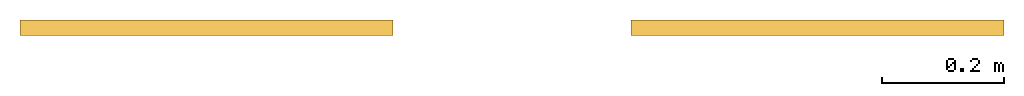
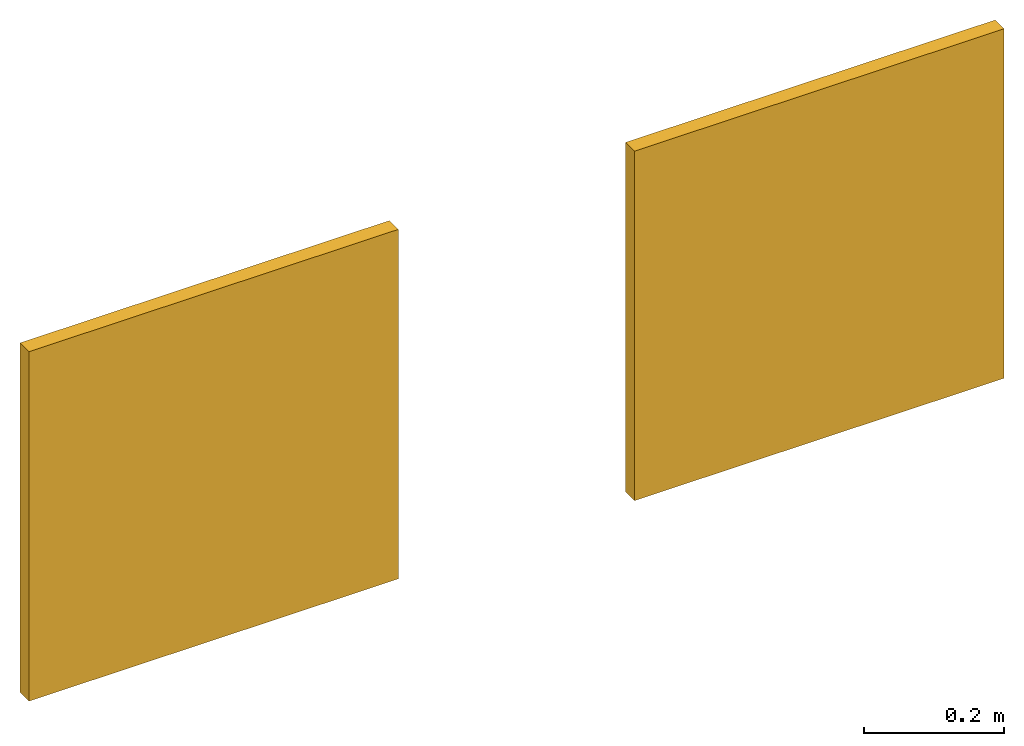
# Not in any storey: 2 windows.
"""IFC4 model written with IfcOpenShell, lengths in feet."""

from ifc_helpers import new_model, entity, si_unit, converted_unit, frame, origin_with_axes, place, context, project, polyline, outline, extrude, shape, source, transform, mapped, type_object, type_shapes, element, save


model = new_model("IFC4")

# Units and contexts
model_context = context("Model", 3, precision=1e-05, world=origin_with_axes())
plan_context = context("Plan", 2, precision=1e-05, world=origin_with_axes())
ifc_project = project(units=[converted_unit("LENGTHUNIT", "foot", entity("IfcReal", 0.3048), si_unit("LENGTHUNIT", "METRE"), dimensions=[1, 0, 0, 0, 0, 0, 0]), converted_unit("AREAUNIT", "square foot", entity("IfcReal", 0.09290304), si_unit("AREAUNIT", "SQUARE_METRE"), dimensions=[2, 0, 0, 0, 0, 0, 0]), converted_unit("VOLUMEUNIT", "cubic foot", entity("IfcReal", 0.0283168467116885), si_unit("VOLUMEUNIT", "CUBIC_METRE"), dimensions=[3, 0, 0, 0, 0, 0, 0])], contexts=[model_context, plan_context])

# Windows
window_type = type_object("IfcWindowType", Name="Cube", PredefinedType="NOTDEFINED")
shared_shape = source(origin_with_axes(), model_context, None, "SweptSolid", [
    extrude(outline(polyline([(-1.00000011013562, -0.0416666875517587), (0.99999991458232, -0.0416666875517587), (1.00000011013562, 0.0416666875517587), (-0.99999991458232, 0.0416666875517587), (-1.00000011013562, -0.0416666875517587)])), frame((4.39994917141171e-07, 5.37771565394765e-07, 2.00000002471794), z_axis=(0.0, 0.0, -1.0), x_axis=(-1.0, 0.0, 0.0)), (0.0, 0.0, 1.0), 2.00000000376181),
])
type_shapes(window_type, [shared_shape])
for number, where, z_axis, x_axis, name in (
    (1, (6.91678267451409, 0.0399980129395414, 3.19741607650997), (0.0, 0.0, 1.0), (1.0, 0.0, 0.0), "Window"),
    (2, (10.1949919865826, 0.0399980129395414, 3.19741607650997), (0.0, 0.0, 1.0), (1.0, 0.0, 0.0), "Window"),
):
    element("IfcWindow", number, at=place(None, frame(where, z_axis=z_axis, x_axis=x_axis)), type_object=window_type, Name=name, shapes=[
        shape(model_context, None, "MappedRepresentation", [mapped(shared_shape, transform((0.0, 0.0, 0.0), x_axis=(1.0, 0.0, 0.0), y_axis=(0.0, 1.0, 0.0), z_axis=(0.0, 0.0, 1.0), scale=1.0))]),
    ])

save(model, "model.ifc")
